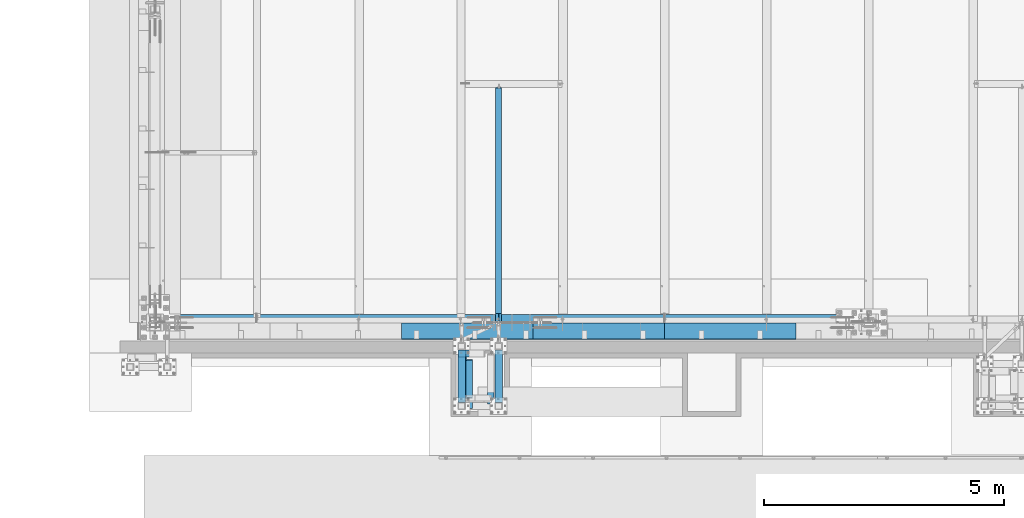
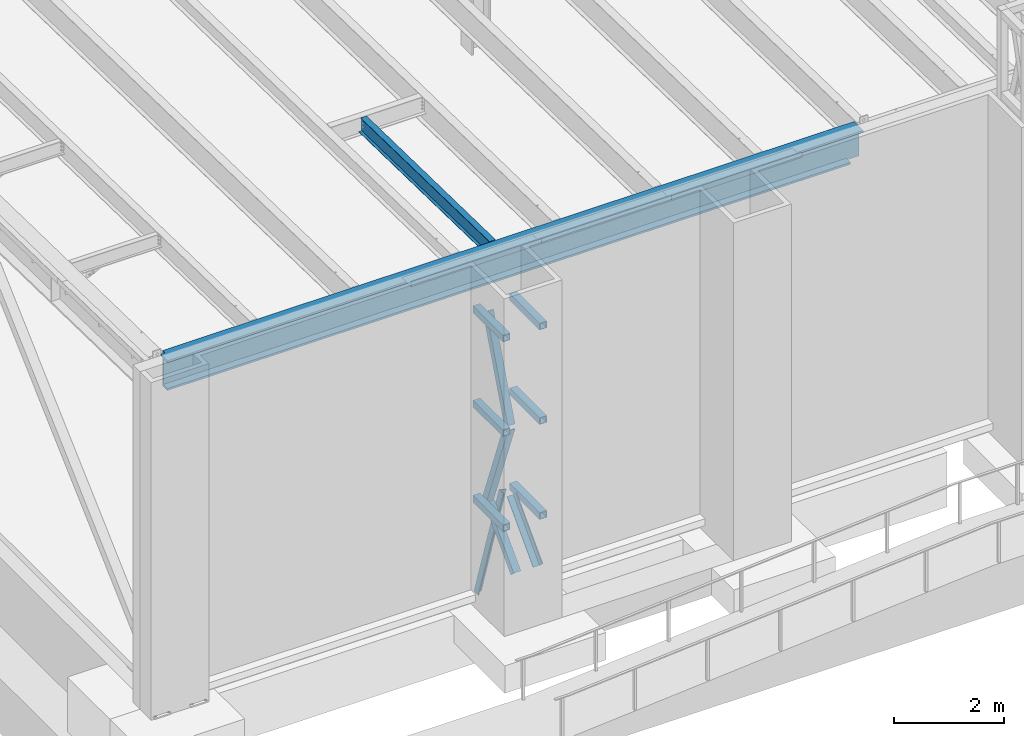
# One storey, part 1037 of 1763: 11 beams, 5 members, 3 elements without a shape of their own.
"""IFC2X3 building model written with IfcOpenShell, lengths in millimetres."""

from ifc_helpers import new_model, si_unit, frame, origin_with_axes, place, context, subcontext, project, spatial, faceted_brep, material, type_object, element, aggregate, save


model = new_model("IFC2X3")

# Units and contexts
model_context = context("Model", 3, precision=1e-05, world=origin_with_axes())
body_context = subcontext(model_context, "Body", "Model", "MODEL_VIEW")
ifc_project = project(units=[si_unit("LENGTHUNIT", "METRE", prefix="MILLI"), si_unit("AREAUNIT", "SQUARE_METRE"), si_unit("VOLUMEUNIT", "CUBIC_METRE"), si_unit("MASSUNIT", "GRAM", prefix="KILO"), si_unit("TIMEUNIT", "SECOND"), si_unit("PLANEANGLEUNIT", "RADIAN"), si_unit("SOLIDANGLEUNIT", "STERADIAN"), si_unit("THERMODYNAMICTEMPERATUREUNIT", "DEGREE_CELSIUS"), si_unit("LUMINOUSINTENSITYUNIT", "LUMEN")], contexts=[model_context])

# Site, building, storey
site_placement = place(None, origin_with_axes())
site = spatial("IfcSite", under=ifc_project, at=site_placement, CompositionType="ELEMENT")
building_placement = place(site_placement, origin_with_axes())
building = spatial("IfcBuilding", under=site, at=building_placement, Name="Undefined", CompositionType="ELEMENT")
storey_placement = place(building_placement, origin_with_axes())
storey = spatial("IfcBuildingStorey", under=building, at=storey_placement, Name="Undefined", CompositionType="ELEMENT", Elevation=0.0)

# Assembly, members, beams
assembly_1_placement = place(storey_placement, origin_with_axes())
assembly_1 = element("IfcElementAssembly", 1, at=assembly_1_placement, inside=storey, Name="FRAME", AssemblyPlace="NOTDEFINED", PredefinedType="RIGID_FRAME")
ifc_material_1 = material(Name="STEEL/A36")
member_type = type_object("IfcMemberType", Name="L6X6X7/8", PredefinedType="NOTDEFINED")
member_1_placement = place(assembly_1_placement, frame((-80831.7622248702, -15224.1242675181, 9354.542188), z_axis=(1.0, 0.0, 0.0), x_axis=(0.0, 0.354716320047586, 0.934973974125429)))
member_1 = element("IfcMember", 2, at=member_1_placement, type_object=member_type, material=ifc_material_1, Name="V. BRACE", ObjectType="L6X6X7/8", context=body_context, shape_type="Brep", body=[
    faceted_brep([(9.09494701772928e-13, 76.2000000000007, -76.2000000000844), (0.0, 76.2000000000007, 76.2000000000771), (2219.80276448098, 76.2000000001062, 76.1999999999971), (2219.80276448098, 76.2000000001062, -76.1999999999971), (0.0, 53.9750000000004, 76.2000000000771), (2219.80276448098, 53.9750000001222, 76.1999999999971), (1.81898940354586e-12, 53.9750000000004, -53.9750000000604), (2219.80276448098, 53.9750000001222, -53.9750000000058), (1.81898940354586e-12, -76.2000000000007, -53.9750000000604), (2219.80276448099, -76.1999999997752, -53.9750000000058), (9.09494701772928e-13, -76.2000000000007, -76.2000000000844), (2219.80276448099, -76.1999999997752, -76.1999999999971)], [[[0, 1, 2, 3]], [[1, 4, 5, 2]], [[4, 6, 7, 5]], [[6, 8, 9, 7]], [[8, 10, 11, 9]], [[10, 0, 3, 11]], [[5, 7, 9, 11, 3, 2]], [[10, 8, 6, 4, 1, 0]]]),
])
member_2_placement = place(assembly_1_placement, frame((-80831.7622248702, -14436.724, 7238.22190623797), z_axis=(1.0, 0.0, 0.0), x_axis=(0.0, -0.357374206981423, 0.933961281951452)))
member_2 = element("IfcMember", 3, at=member_2_placement, type_object=member_type, material=ifc_material_1, Name="V. BRACE", ObjectType="L6X6X7/8", context=body_context, shape_type="Brep", body=[
    faceted_brep([(1.81898940354586e-12, -76.2000000000007, -53.9750000000604), (9.09494701772928e-13, -76.2000000000007, -76.2000000000844), (2203.29349780015, -76.2000000014305, -76.1999999999971), (2203.29349780015, -76.2000000014305, -53.9750000000058), (1.81898940354586e-12, 53.9750000000004, -53.9750000000604), (2203.29349780012, 53.9749999985361, -53.9750000000058), (0.0, 53.9750000000004, 76.2000000000771), (2203.29349780012, 53.9749999985361, 76.1999999999971), (0.0, 76.2000000000007, 76.2000000000771), (2203.29349780012, 76.1999999985292, 76.1999999999971), (9.09494701772928e-13, 76.2000000000007, -76.2000000000844), (2203.29349780012, 76.1999999985292, -76.1999999999971)], [[[0, 1, 2, 3]], [[4, 0, 3, 5]], [[6, 4, 5, 7]], [[8, 6, 7, 9]], [[1, 0, 4, 6, 8, 10]], [[1, 10, 11, 2]], [[7, 5, 3, 2, 11, 9]], [[10, 8, 9, 11]]]),
])
member_3_placement = place(assembly_1_placement, frame((-80365.0371272139, -15452.7242675181, 6184.89897423299), z_axis=(-1.0, 0.0, 0.0), x_axis=(0.0, 0.691217150059911, 0.722647114062635)))
member_3 = element("IfcMember", 4, at=member_3_placement, type_object=member_type, material=ifc_material_1, Name="V. BRACE", ObjectType="L6X6X7/8", context=body_context, shape_type="Brep", body=[
    faceted_brep([(1.81898940354586e-12, -76.2000000000007, -53.9750000000604), (9.09494701772928e-13, -76.2000000000007, -76.2000000000844), (1385.03092654575, -76.1999999994277, -76.1999999999971), (1385.03092654575, -76.1999999994277, -53.9750000000058), (1.81898940354586e-12, 53.9750000000004, -53.9750000000604), (1385.0309265457, 53.9750000005115, -53.9750000000058), (0.0, 53.9750000000004, 76.2000000000771), (1385.0309265457, 53.9750000005115, 76.1999999999971), (0.0, 76.2000000000007, 76.2000000000771), (1385.03092654569, 76.2000000005009, 76.1999999999971), (9.09494701772928e-13, 76.2000000000007, -76.2000000000844), (1385.03092654569, 76.2000000005009, -76.1999999999971)], [[[0, 1, 2, 3]], [[4, 0, 3, 5]], [[6, 4, 5, 7]], [[8, 6, 7, 9]], [[1, 0, 4, 6, 8, 10]], [[1, 10, 11, 2]], [[7, 5, 3, 2, 11, 9]], [[10, 8, 9, 11]]]),
])
member_4_placement = place(assembly_1_placement, frame((-80831.7622248702, -15452.7238092148, 6184.9), z_axis=(1.0, 0.0, 0.0), x_axis=(0.0, 0.691217150059911, 0.722647114062635)))
member_4 = element("IfcMember", 5, at=member_4_placement, type_object=member_type, material=ifc_material_1, Name="V. BRACE", ObjectType="L6X6X7/8", context=body_context, shape_type="Brep", body=[
    faceted_brep([(1.81898940354586e-12, -76.2000000000007, -53.9750000000604), (9.09494701772928e-13, -76.2000000000007, -76.2000000000844), (1385.02986859929, -76.2000000005319, -76.1999999999971), (1385.02986859929, -76.2000000005319, -53.9750000000058), (1.81898940354586e-12, 53.9750000000004, -53.9750000000604), (1385.02986859926, 53.9749999994528, -53.9750000000058), (0.0, 53.9750000000004, 76.2000000000771), (1385.02986859926, 53.9749999994528, 76.1999999999971), (0.0, 76.2000000000007, 76.2000000000771), (1385.02986859925, 76.1999999994478, 76.1999999999971), (9.09494701772928e-13, 76.2000000000007, -76.2000000000844), (1385.02986859925, 76.1999999994478, -76.1999999999971)], [[[0, 1, 2, 3]], [[4, 0, 3, 5]], [[6, 4, 5, 7]], [[8, 6, 7, 9]], [[1, 0, 4, 6, 8, 10]], [[1, 10, 11, 2]], [[7, 5, 3, 2, 11, 9]], [[10, 8, 9, 11]]]),
])
member_5_placement = place(assembly_1_placement, frame((-80984.1622736983, -14360.5242675181, 5067.30000004768), z_axis=(0.0, -1.0, 0.0), x_axis=(0.24575404812011, 0.0, 0.969332217473751)))
member_5 = element("IfcMember", 6, at=member_5_placement, type_object=member_type, material=ifc_material_1, Name="V. BRACE", ObjectType="L6X6X7/8", context=body_context, shape_type="Brep", body=[
    faceted_brep([(58.6244028822784, 76.1999999994587, -76.2000000000007), (58.6244028822784, 76.1999999994587, 76.2000000000007), (2209.86127146497, 76.1999999862164, 76.2000000000007), (2209.86127146497, 76.1999999862164, -76.2000000000007), (58.6261393079949, 53.9749999995111, 76.2000000000007), (2209.86127146496, 53.9749999862543, 76.2000000000007), (58.6261393079949, 53.9749999995111, -53.9750000000004), (2209.86127146496, 53.9749999862543, -53.9750000000004), (58.6363098015081, -76.2000000002299, -53.9750000000004), (2209.8612714649, -76.2000000134722, -53.9750000000004), (58.6363098015081, -76.2000000002299, -76.2000000000007), (2209.8612714649, -76.2000000134722, -76.2000000000007)], [[[0, 1, 2, 3]], [[1, 4, 5, 2]], [[4, 6, 7, 5]], [[6, 8, 9, 7]], [[8, 10, 11, 9]], [[10, 0, 3, 11]], [[5, 7, 9, 11, 3, 2]], [[10, 8, 6, 4, 1, 0]]]),
])
ifc_material_2 = material()
beam_type_1 = type_object("IfcBeamType", Name="HSS6X6X5/8", PredefinedType="NOTDEFINED")
beam_1_placement = place(assembly_1_placement, frame((-80212.6372248702, -15452.7242675181, 11430.0), z_axis=(0.0, 0.0, 1.0), x_axis=(0.0, 1.0, 0.0)))
beam_1 = element("IfcBeam", 7, at=beam_1_placement, type_object=beam_type_1, material=ifc_material_2, Name="BEAM", ObjectType="HSS6X6X5/8", context=body_context, shape_type="Brep", body=[
    faceted_brep([(76.1999511718459, 60.3250000000007, -60.3250000000007), (76.1999511718459, -60.3250000000007, -60.3250000000007), (1168.4, -60.3249999999971, -60.3250000000007), (1168.4, 60.3249999999971, -60.3250000000007), (76.1999511718459, -60.3250000000007, 60.3250000000007), (1168.4, -60.3249999999971, 60.3250000000007), (76.1999511718459, 60.3250000000007, 60.3250000000007), (1168.4, 60.3249999999971, 60.3250000000007), (76.1999511718459, 76.2000000000007, -76.2000000000007), (76.1999511718459, 76.2000000000007, 76.2000000000007), (1168.4, 76.1999999999971, 76.2000000000007), (1168.4, 76.1999999999971, -76.2000000000007), (76.1999511718459, -76.2000000000007, 76.2000000000007), (1168.4, -76.1999999999971, 76.2000000000007), (76.1999511718459, -76.2000000000007, -76.2000000000007), (1168.4, -76.1999999999971, -76.2000000000007)], [[[0, 1, 2, 3]], [[1, 4, 5, 2]], [[4, 6, 7, 5]], [[6, 0, 3, 7]], [[8, 9, 10, 11]], [[9, 12, 13, 10]], [[12, 14, 15, 13]], [[14, 8, 11, 15]], [[13, 15, 11, 10], [5, 7, 3, 2]], [[14, 12, 9, 8], [6, 4, 1, 0]]]),
])
beam_2_placement = place(assembly_1_placement, frame((-80984.1622248702, -15452.7242675181, 11430.0), z_axis=(0.0, 0.0, 1.0), x_axis=(0.0, 1.0, 0.0)))
beam_2 = element("IfcBeam", 8, at=beam_2_placement, type_object=beam_type_1, material=ifc_material_2, Name="BEAM", ObjectType="HSS6X6X5/8", context=body_context, shape_type="Brep", body=[
    faceted_brep([(76.1999511718459, 60.3250000000007, -60.3250000000007), (76.1999511718459, -60.3250000000007, -60.3250000000007), (1168.4, -60.3249999999971, -60.3250000000007), (1168.4, 60.3249999999971, -60.3250000000007), (76.1999511718459, -60.3250000000007, 60.3250000000007), (1168.4, -60.3249999999971, 60.3250000000007), (76.1999511718459, 60.3250000000007, 60.3250000000007), (1168.4, 60.3249999999971, 60.3250000000007), (76.1999511718459, 76.2000000000007, -76.2000000000007), (76.1999511718459, 76.2000000000007, 76.2000000000007), (1168.4, 76.1999999999971, 76.2000000000007), (1168.4, 76.1999999999971, -76.2000000000007), (76.1999511718459, -76.2000000000007, 76.2000000000007), (1168.4, -76.1999999999971, 76.2000000000007), (76.1999511718459, -76.2000000000007, -76.2000000000007), (1168.4, -76.1999999999971, -76.2000000000007)], [[[0, 1, 2, 3]], [[1, 4, 5, 2]], [[4, 6, 7, 5]], [[6, 0, 3, 7]], [[8, 9, 10, 11]], [[9, 12, 13, 10]], [[12, 14, 15, 13]], [[14, 8, 11, 15]], [[13, 15, 11, 10], [5, 7, 3, 2]], [[14, 12, 9, 8], [6, 4, 1, 0]]]),
])
beam_3_placement = place(assembly_1_placement, frame((-80212.6372248702, -15452.7242675181, 9325.9676945918), z_axis=(0.0, 0.0, 1.0), x_axis=(0.0, 1.0, 0.0)))
beam_3 = element("IfcBeam", 9, at=beam_3_placement, type_object=beam_type_1, material=ifc_material_2, Name="BEAM", ObjectType="HSS6X6X5/8", context=body_context, shape_type="Brep", body=[
    faceted_brep([(76.1999511718459, 60.3250000000007, -60.3250000000007), (76.1999511718459, -60.3250000000007, -60.3250000000007), (1168.4, -60.3249999999971, -60.3250000000007), (1168.4, 60.3249999999971, -60.3250000000007), (76.1999511718459, -60.3250000000007, 60.3250000000007), (1168.4, -60.3249999999971, 60.3250000000007), (76.1999511718459, 60.3250000000007, 60.3250000000007), (1168.4, 60.3249999999971, 60.3250000000007), (76.1999511718459, 76.2000000000007, -76.2000000000007), (76.1999511718459, 76.2000000000007, 76.2000000000007), (1168.4, 76.1999999999971, 76.2000000000007), (1168.4, 76.1999999999971, -76.2000000000007), (76.1999511718459, -76.2000000000007, 76.2000000000007), (1168.4, -76.1999999999971, 76.2000000000007), (76.1999511718459, -76.2000000000007, -76.2000000000007), (1168.4, -76.1999999999971, -76.2000000000007)], [[[0, 1, 2, 3]], [[1, 4, 5, 2]], [[4, 6, 7, 5]], [[6, 0, 3, 7]], [[8, 9, 10, 11]], [[9, 12, 13, 10]], [[12, 14, 15, 13]], [[14, 8, 11, 15]], [[13, 15, 11, 10], [5, 7, 3, 2]], [[14, 12, 9, 8], [6, 4, 1, 0]]]),
])
beam_4_placement = place(assembly_1_placement, frame((-80984.1622248702, -15452.7242675181, 9325.9676945918), z_axis=(0.0, 0.0, 1.0), x_axis=(0.0, 1.0, 0.0)))
beam_4 = element("IfcBeam", 10, at=beam_4_placement, type_object=beam_type_1, material=ifc_material_2, Name="BEAM", ObjectType="HSS6X6X5/8", context=body_context, shape_type="Brep", body=[
    faceted_brep([(76.1999511718459, 60.3250000000007, -60.3250000000007), (76.1999511718459, -60.3250000000007, -60.3250000000007), (1168.4, -60.3249999999971, -60.3250000000007), (1168.4, 60.3249999999971, -60.3250000000007), (76.1999511718459, -60.3250000000007, 60.3250000000007), (1168.4, -60.3249999999971, 60.3250000000007), (76.1999511718459, 60.3250000000007, 60.3250000000007), (1168.4, 60.3249999999971, 60.3250000000007), (76.1999511718459, 76.2000000000007, -76.2000000000007), (76.1999511718459, 76.2000000000007, 76.2000000000007), (1168.4, 76.1999999999971, 76.2000000000007), (1168.4, 76.1999999999971, -76.2000000000007), (76.1999511718459, -76.2000000000007, 76.2000000000007), (1168.4, -76.1999999999971, 76.2000000000007), (76.1999511718459, -76.2000000000007, -76.2000000000007), (1168.4, -76.1999999999971, -76.2000000000007)], [[[0, 1, 2, 3]], [[1, 4, 5, 2]], [[4, 6, 7, 5]], [[6, 0, 3, 7]], [[8, 9, 10, 11]], [[9, 12, 13, 10]], [[12, 14, 15, 13]], [[14, 8, 11, 15]], [[13, 15, 11, 10], [5, 7, 3, 2]], [[14, 12, 9, 8], [6, 4, 1, 0]]]),
])
beam_5_placement = place(assembly_1_placement, frame((-80212.637127214, -15452.7242675181, 7209.43271670378), z_axis=(0.0, 0.0, 1.0), x_axis=(0.0, 1.0, 0.0)))
beam_5 = element("IfcBeam", 11, at=beam_5_placement, type_object=beam_type_1, material=ifc_material_2, Name="BEAM", ObjectType="HSS6X6X5/8", context=body_context, shape_type="Brep", body=[
    faceted_brep([(76.1999511718459, 60.3250000000007, -60.3250000000007), (76.1999511718459, -60.3250000000007, -60.3250000000007), (1168.4, -60.3249999999971, -60.3250000000007), (1168.4, 60.3249999999971, -60.3250000000007), (76.1999511718459, -60.3250000000007, 60.3250000000007), (1168.4, -60.3249999999971, 60.3250000000007), (76.1999511718459, 60.3250000000007, 60.3250000000007), (1168.4, 60.3249999999971, 60.3250000000007), (76.1999511718459, 76.2000000000007, -76.2000000000007), (76.1999511718459, 76.2000000000007, 76.2000000000007), (1168.4, 76.1999999999971, 76.2000000000007), (1168.4, 76.1999999999971, -76.2000000000007), (76.1999511718459, -76.2000000000007, 76.2000000000007), (1168.4, -76.1999999999971, 76.2000000000007), (76.1999511718459, -76.2000000000007, -76.2000000000007), (1168.4, -76.1999999999971, -76.2000000000007)], [[[0, 1, 2, 3]], [[1, 4, 5, 2]], [[4, 6, 7, 5]], [[6, 0, 3, 7]], [[8, 9, 10, 11]], [[9, 12, 13, 10]], [[12, 14, 15, 13]], [[14, 8, 11, 15]], [[13, 15, 11, 10], [5, 7, 3, 2]], [[14, 12, 9, 8], [6, 4, 1, 0]]]),
])
beam_6_placement = place(assembly_1_placement, frame((-80984.162127214, -15452.7242675181, 7209.43271670378), z_axis=(0.0, 0.0, 1.0), x_axis=(0.0, 1.0, 0.0)))
beam_6 = element("IfcBeam", 12, at=beam_6_placement, type_object=beam_type_1, material=ifc_material_2, Name="BEAM", ObjectType="HSS6X6X5/8", context=body_context, shape_type="Brep", body=[
    faceted_brep([(76.1999511718459, 60.3250000000007, -60.3250000000007), (76.1999511718459, -60.3250000000007, -60.3250000000007), (1168.4, -60.3249999999971, -60.3250000000007), (1168.4, 60.3249999999971, -60.3250000000007), (76.1999511718459, -60.3250000000007, 60.3250000000007), (1168.4, -60.3249999999971, 60.3250000000007), (76.1999511718459, 60.3250000000007, 60.3250000000007), (1168.4, 60.3249999999971, 60.3250000000007), (76.1999511718459, 76.2000000000007, -76.2000000000007), (76.1999511718459, 76.2000000000007, 76.2000000000007), (1168.4, 76.1999999999971, 76.2000000000007), (1168.4, 76.1999999999971, -76.2000000000007), (76.1999511718459, -76.2000000000007, 76.2000000000007), (1168.4, -76.1999999999971, 76.2000000000007), (76.1999511718459, -76.2000000000007, -76.2000000000007), (1168.4, -76.1999999999971, -76.2000000000007)], [[[0, 1, 2, 3]], [[1, 4, 5, 2]], [[4, 6, 7, 5]], [[6, 0, 3, 7]], [[8, 9, 10, 11]], [[9, 12, 13, 10]], [[12, 14, 15, 13]], [[14, 8, 11, 15]], [[13, 15, 11, 10], [5, 7, 3, 2]], [[14, 12, 9, 8], [6, 4, 1, 0]]]),
])
aggregate(assembly_1, [member_1, member_2, member_3, member_4, member_5, beam_1, beam_2, beam_3, beam_4, beam_5, beam_6])

# Assembly, beam
assembly_2_placement = place(storey_placement, origin_with_axes())
assembly_2 = element("IfcElementAssembly", 13, at=assembly_2_placement, inside=storey, Name="BEAM", AssemblyPlace="NOTDEFINED", PredefinedType="RIGID_FRAME")
ifc_material_3 = material(Name="STEEL/A992")
beam_type_2 = type_object("IfcBeamType", Name="W14X22", PredefinedType="NOTDEFINED")
beam_7_placement = place(assembly_2_placement, frame((-80212.6371775587, -13719.6498400448, 12030.1131480899), z_axis=(0.0, 0.0209013539966291, 0.999781542838788), x_axis=(0.0, 0.999781542776098, -0.0209013569953182)))
beam_7 = element("IfcBeam", 14, at=beam_7_placement, type_object=beam_type_2, material=ifc_material_3, Name="BEAM", ObjectType="W14X22", context=body_context, shape_type="Brep", body=[
    faceted_brep([(31.7472016101747, -3.17500000000291, -166.687500000142), (31.7472016101747, -63.5, -166.687500000142), (4968.01631217715, -63.5, -166.68750000177), (4968.01631217715, -3.17500000000291, -166.68750000177), (31.9131423743456, -63.5, -174.625000000149), (4968.18225294133, -63.5, -174.625000001777), (31.9131423743456, 63.5, -174.625000000149), (4968.18225294133, 63.5, -174.625000001777), (31.7472016101747, 63.5, -166.687500000142), (4968.01631217715, 63.5, -166.68750000177), (4894.6815561373, -63.5, 174.624999998528), (4894.6815561373, -63.5, 166.687499998525), (4894.6815561373, -3.17500000000291, 166.687499998525), (4894.68155613729, -3.17500000000291, 155.3150014783), (4894.68155613729, 3.17500000000291, 155.3150014783), (4894.6815561373, 3.17500000000291, 166.687499998525), (4894.6815561373, 63.5, 166.687499998525), (4894.6815561373, 63.5, 174.624999998528), (4895.64828605988, -3.17500000000291, 150.454921960243), (4895.64828605988, 3.17500000000291, 150.454921960243), (4898.40129996036, -3.17500000000291, 146.334745492079), (4898.40129996036, 3.17500000000291, 146.334745492079), (4902.52147642852, -3.17500000000291, 143.581731591592), (4902.52147642852, 3.17500000000291, 143.581731591592), (4907.38155594658, -3.17500000000291, 142.615001669001), (4907.38155594658, 3.17500000000291, 142.615001669001), (4961.55005787953, -3.17500000000291, 142.615001668983), (4961.55005787953, 3.17500000000291, 142.615001668983), (4968.01631217715, 3.17500000000291, -166.68750000177), (31.7472016101747, 3.17500000000291, -166.687500000142), (179.172525272308, -3.17500000000291, 118.181727786434), (179.172525272308, 3.17500000000291, 118.181727786434), (174.312445754249, 3.17500000000291, 117.214997863844), (174.312445754249, -3.17500000000291, 117.214997863844), (183.292701740473, -3.17500000000291, 120.934741686915), (183.292701740473, 3.17500000000291, 120.934741686915), (186.045715640957, -3.17500000000291, 125.054918155078), (186.045715640957, 3.17500000000291, 125.054918155078), (187.012445563551, -3.17500000000291, 129.914997673133), (187.012445563551, 3.17500000000291, 129.914997673133), (25.811957837479, 3.17500000000291, 117.214997863894), (187.012445563561, 3.17500000000291, 166.687500000075), (187.012445563561, 63.5, 166.687500000075), (187.012445563563, 63.5, 174.62500000008), (187.012445563563, -63.5, 174.62500000008), (187.012445563561, -63.5, 166.687500000075), (187.012445563561, -3.17500000000291, 166.687500000075), (25.811957837479, -3.17500000000291, 117.214997863894)], [[[0, 1, 2, 3]], [[1, 4, 5, 2]], [[4, 6, 7, 5]], [[6, 8, 9, 7]], [[10, 11, 12, 13, 14, 15, 16, 17]], [[18, 19, 14, 13]], [[20, 21, 19, 18]], [[22, 23, 21, 20]], [[24, 25, 23, 22]], [[26, 27, 25, 24]], [[3, 2, 5, 7, 9, 28, 27, 26]], [[8, 29, 28, 9]], [[30, 31, 32, 33]], [[34, 35, 31, 30]], [[36, 37, 35, 34]], [[38, 39, 37, 36]], [[15, 14, 19, 21, 23, 25, 27, 28, 29, 40, 32, 31, 35, 37, 39, 41]], [[16, 15, 41, 42]], [[17, 16, 42, 43]], [[10, 17, 43, 44]], [[11, 10, 44, 45]], [[12, 11, 45, 46]], [[44, 43, 42, 41, 39, 38, 46, 45]], [[36, 34, 30, 33, 47, 0, 3, 26, 24, 22, 20, 18, 13, 12, 46, 38]], [[29, 8, 6, 4, 1, 0, 47, 40]], [[33, 32, 40, 47]]]),
])
aggregate(assembly_2, [beam_7])

# Assembly, beams
assembly_3_placement = place(storey_placement, origin_with_axes())
assembly_3 = element("IfcElementAssembly", 15, at=assembly_3_placement, inside=storey, Name="BEAM", AssemblyPlace="NOTDEFINED", PredefinedType="RIGID_FRAME")
beam_type_3 = type_object("IfcBeamType", PredefinedType="NOTDEFINED")
beam_8_placement = place(assembly_3_placement, frame((-75380.2872736983, -13728.6998186171, 12207.875), z_axis=(-1.0, 0.0, 0.0), x_axis=(0.0, -1.0, 0.0)))
beam_8 = element("IfcBeam", 16, at=beam_8_placement, type_object=beam_type_3, material=ifc_material_1, Name="BENT_PLATE", context=body_context, shape_type="Brep", body=[
    faceted_brep([(2.91038304567337e-11, -3.17499999963729, -1371.60000000396), (-2.91038304567337e-11, -3.17500000036489, 1371.60000000395), (-2.91038304567337e-11, 3.17499999963184, 1371.60000000395), (2.91038304567337e-11, 3.17500000035943, -1371.60000000396), (330.19998779297, 3.17499999999927, 1371.60000000001), (330.19998779297, 3.17499999999927, -1371.60000000001), (336.549987792969, -3.17499999999927, -1371.60000000001), (336.549987792969, -3.17499999999927, 1371.60000000001), (330.19998779297, 123.825000000001, 1371.60000000001), (330.19998779297, 123.825000000001, -1371.60000000001), (336.549987792969, 123.825000000001, 1371.60000000001), (336.549987792969, 123.825000000001, -1371.60000000001)], [[[0, 1, 2, 3]], [[3, 2, 4, 5]], [[1, 0, 6, 7]], [[5, 4, 8, 9]], [[4, 2, 1, 7, 10, 8]], [[7, 6, 11, 10]], [[6, 0, 3, 5, 9, 11]], [[10, 11, 9, 8]]]),
])
beam_9_placement = place(assembly_3_placement, frame((-78123.4872736983, -13728.6998186171, 12207.875), z_axis=(-1.0, 0.0, 0.0), x_axis=(0.0, -1.0, 0.0)))
beam_9 = element("IfcBeam", 17, at=beam_9_placement, type_object=beam_type_3, material=ifc_material_1, Name="BENT_PLATE", context=body_context, shape_type="Brep", body=[
    faceted_brep([(2.91038304567337e-11, -3.17499999963729, -1371.60000000396), (-2.91038304567337e-11, -3.17500000036489, 1371.60000000395), (-2.91038304567337e-11, 3.17499999963184, 1371.60000000395), (2.91038304567337e-11, 3.17500000035943, -1371.60000000396), (330.19998779297, 3.17499999999927, 1371.60000000001), (330.19998779297, 3.17499999999927, -1371.60000000001), (336.549987792969, -3.17499999999927, -1371.60000000001), (336.549987792969, -3.17499999999927, 1371.60000000001), (330.19998779297, 123.825000000001, 1371.60000000001), (330.19998779297, 123.825000000001, -1371.60000000001), (336.549987792969, 123.825000000001, 1371.60000000001), (336.549987792969, 123.825000000001, -1371.60000000001)], [[[0, 1, 2, 3]], [[3, 2, 4, 5]], [[1, 0, 6, 7]], [[5, 4, 8, 9]], [[4, 2, 1, 7, 10, 8]], [[7, 6, 11, 10]], [[6, 0, 3, 5, 9, 11]], [[10, 11, 9, 8]]]),
])
beam_10_placement = place(assembly_3_placement, frame((-80866.6872736983, -13728.6998186171, 12207.875), z_axis=(-1.0, 0.0, 0.0), x_axis=(0.0, -1.0, 0.0)))
beam_10 = element("IfcBeam", 18, at=beam_10_placement, type_object=beam_type_3, material=ifc_material_1, Name="BENT_PLATE", context=body_context, shape_type="Brep", body=[
    faceted_brep([(2.91038304567337e-11, -3.17499999963729, -1371.60000000396), (-2.91038304567337e-11, -3.17500000036489, 1371.60000000395), (-2.91038304567337e-11, 3.17499999963184, 1371.60000000395), (2.91038304567337e-11, 3.17500000035943, -1371.60000000396), (330.19998779297, 3.17499999999927, 1371.60000000001), (330.19998779297, 3.17499999999927, -1371.60000000001), (336.549987792969, -3.17499999999927, -1371.60000000001), (336.549987792969, -3.17499999999927, 1371.60000000001), (330.19998779297, 123.825000000001, 1371.60000000001), (330.19998779297, 123.825000000001, -1371.60000000001), (336.549987792969, 123.825000000001, 1371.60000000001), (336.549987792969, 123.825000000001, -1371.60000000001)], [[[0, 1, 2, 3]], [[3, 2, 4, 5]], [[1, 0, 6, 7]], [[5, 4, 8, 9]], [[4, 2, 1, 7, 10, 8]], [[7, 6, 11, 10]], [[6, 0, 3, 5, 9, 11]], [[10, 11, 9, 8]]]),
])
beam_type_4 = type_object("IfcBeamType", Name="W24X229", PredefinedType="NOTDEFINED")
beam_11_placement = place(assembly_3_placement, frame((-87375.4372736983, -13715.9998186171, 11874.5), z_axis=(0.0, 0.0, 1.0), x_axis=(1.0, 0.0, 0.0)))
beam_11 = element("IfcBeam", 19, at=beam_11_placement, type_object=beam_type_4, material=ifc_material_3, Name="BEAM", ObjectType="W24X229", context=body_context, shape_type="Brep", body=[
    faceted_brep([(14498.400012207, 11.90625, -285.75), (14498.400012207, 11.9062500000182, -330.200000000001), (14498.400012207, 166.6875, -330.200000000001), (14498.400012207, 166.6875, -285.75), (14770.1, 11.9062500000182, -285.749999999998), (14770.1, 11.9062500000182, -330.200000000001), (114.300000000003, -11.90625, -285.75), (114.300000000003, -166.6875, -285.75), (14498.400012207, -166.6875, -285.75), (14498.400012207, -11.90625, -285.75), (114.300000000003, -166.6875, -330.200000000001), (14498.400012207, -166.6875, -330.200000000001), (14498.400012207, -11.1125000000102, -330.200000000001), (14498.400012207, -11.1125000000102, -285.750000000004), (14770.1, -11.1125000000102, -285.750000000004), (14770.1, -11.1125000000102, -330.200000000001), (14770.1, -11.90625, -285.750000000004), (14770.1, -11.90625, 285.75), (114.300000000003, -11.90625, 285.75), (114.300000000003, -166.6875, 285.75), (14770.1, -166.6875, 285.75), (114.300000000003, -166.6875, 330.200000000001), (14770.1, -166.6875, 330.200000000001), (14770.1, 166.6875, 330.200000000001), (14770.1, 166.6875, 285.75), (203.199998474127, 166.6875, 285.75), (203.199998474127, 166.6875, 330.200000000001), (203.199998474127, 88.9000015258935, 330.200000000001), (114.300000000003, 88.9000015258935, 330.200000000001), (212.957861076386, 166.6875, -285.75), (212.957861076386, 166.6875, -330.200000000001), (212.957861076386, 11.9062499999964, -330.200000000001), (212.957861076386, 11.9062499999964, -285.75), (114.300000000003, 11.9062499999964, -330.200000000001), (114.300000000003, 11.90625, -285.75), (114.300000000003, 88.9000015258935, 285.75), (114.300000000003, 11.90625, 285.75), (114.300000000003, 11.90625, -222.249999999985), (203.199998474127, 88.9000015258935, 285.75), (14770.1, 11.90625, 285.75)], [[[0, 1, 2, 3]], [[4, 5, 1, 0]], [[6, 7, 8, 9]], [[7, 10, 11, 8]], [[8, 11, 12, 13, 9]], [[14, 13, 12, 15]], [[16, 9, 13, 14]], [[17, 18, 6, 9, 16]], [[19, 18, 17, 20]], [[21, 19, 20, 22]], [[23, 24, 25, 26]], [[21, 22, 23, 26, 27, 28]], [[29, 30, 31, 32]], [[32, 31, 33, 34]], [[10, 7, 6, 18, 19, 21, 28, 35, 36, 37, 34, 33]], [[27, 38, 35, 28]], [[26, 25, 38, 27]], [[24, 39, 36, 35, 38, 25]], [[32, 34, 37, 36, 39, 4, 0]], [[29, 32, 0, 3]], [[30, 29, 3, 2]], [[15, 12, 11, 10, 33, 31, 30, 2, 1, 5]], [[39, 24, 23, 22, 20, 17, 16, 14, 15, 5, 4]]]),
])
aggregate(assembly_3, [beam_8, beam_9, beam_10, beam_11])

save(model, "model.ifc")
